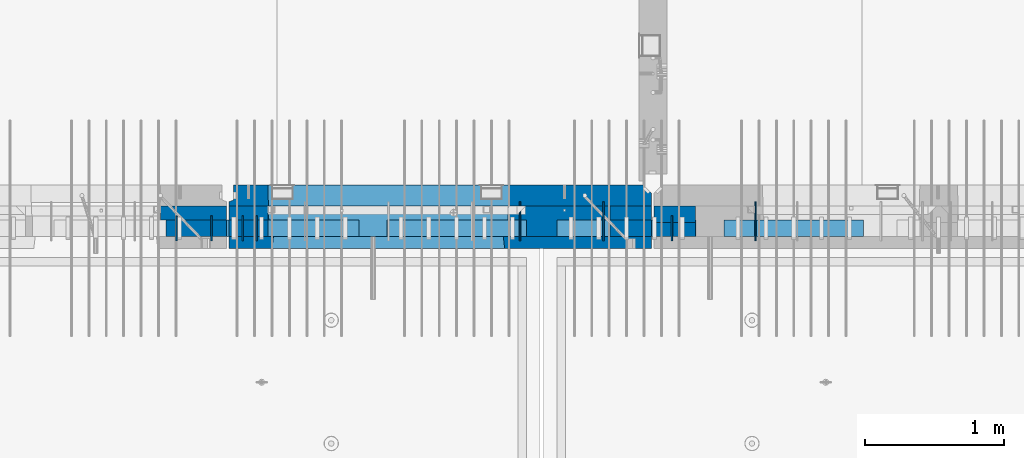
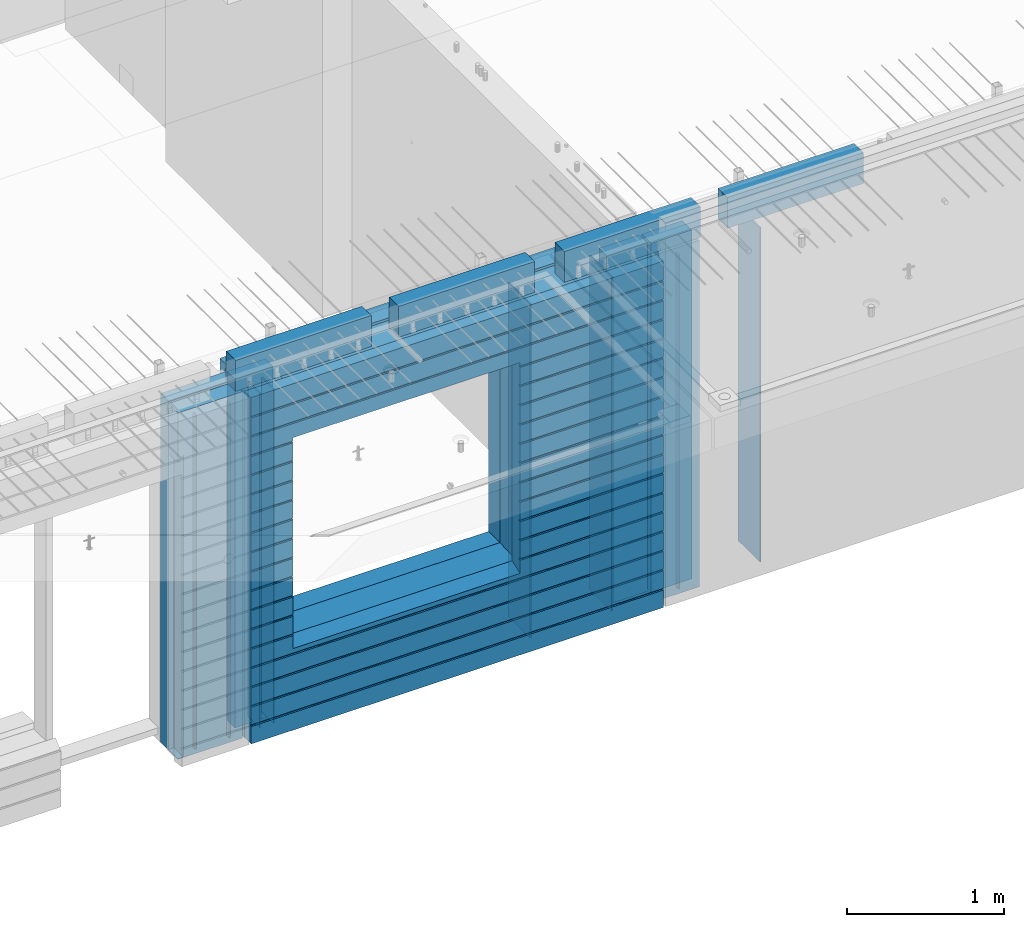
# One storey, part 233 of 350: 23 walls, 10 elements without a shape of their own.
"""IFC2X3 building model written with IfcOpenShell, lengths in millimetres."""

import ifcopenshell
import ifcopenshell.guid

model = None  # the IFC model being written
_history = None  # IfcOwnerHistory: only IFC2X3 demands one
_inside = {}  # id of a spatial element -> (the spatial element, [elements in it])
_under = {}  # id of a project, library or spatial element -> (it, [spatial elements below it])
_declared = {}  # id of a project -> (the project, [libraries it declares])
_typed = {}  # id of a type object -> (the type object, [elements of that type])
_made_of = {}  # id of a material, layer set ... -> (it, [elements and type objects made of it])


def new_model(schema):
    """Start an empty IFC model of exactly this schema.

    Asked for "IFC4X3", IfcOpenShell would pick the latest addendum, in which some entities
    have other attributes; the version numbers below select the first issue.
    IFC2X3 requires an IfcOwnerHistory on every rooted entity: one is made here for all.
    """
    global model, _history
    if schema == "IFC4X3":
        model = ifcopenshell.file(schema_version=(4, 3, 0, 0))
    else:
        model = ifcopenshell.file(schema=schema)
    _inside.clear()
    _under.clear()
    _declared.clear()
    _typed.clear()
    _made_of.clear()
    _history = None
    if model.schema == "IFC2X3":
        org = make("IfcOrganization", Name="unknown")
        user = make(
            "IfcPersonAndOrganization",
            ThePerson=make("IfcPerson", FamilyName="unknown"),
            TheOrganization=org,
        )
        app = make(
            "IfcApplication",
            ApplicationDeveloper=org,
            Version="unknown",
            ApplicationFullName="unknown",
            ApplicationIdentifier="unknown",
        )
        _history = make(
            "IfcOwnerHistory",
            OwningUser=user,
            OwningApplication=app,
            ChangeAction="ADDED",
            CreationDate=0,
        )
    return model


def make(cls, **values):
    """One entity of the class cls with the attributes given. An attribute that is None is left unset."""
    return model.create_entity(
        cls, **{name: value for name, value in values.items() if value is not None}
    )


def rooted(cls, **values):
    """An entity with a GlobalId (a new one), such as an element, a storey or a relation."""
    return make(cls, GlobalId=ifcopenshell.guid.new(), OwnerHistory=_history, **values)


def si_unit(unit_type, name, prefix=None):
    """IfcSIUnit, for example si_unit("LENGTHUNIT", "METRE", prefix="MILLI")."""
    return make("IfcSIUnit", UnitType=unit_type, Prefix=prefix, Name=name)


def assignment(units):
    """IfcUnitAssignment: the units of a project."""
    return None if units is None else make("IfcUnitAssignment", Units=units)


def point(xyz):
    """IfcCartesianPoint."""
    return None if xyz is None else make("IfcCartesianPoint", Coordinates=xyz)


def direction(xyz):
    """IfcDirection."""
    return None if xyz is None else make("IfcDirection", DirectionRatios=xyz)


def frame(location, z_axis=None, x_axis=None):
    """IfcAxis2Placement3D, a coordinate frame: its origin and axes. An axis left out is left unset."""
    return make(
        "IfcAxis2Placement3D",
        Location=point(location),
        Axis=direction(z_axis),
        RefDirection=direction(x_axis),
    )


def origin_with_axes():
    """The frame at (0, 0, 0) with the z axis (0, 0, 1) and the x axis (1, 0, 0) written out."""
    return frame((0.0, 0.0, 0.0), z_axis=(0.0, 0.0, 1.0), x_axis=(1.0, 0.0, 0.0))


def place(relative_to, where):
    """IfcLocalPlacement: puts the frame where relative to a parent placement (None: the world)."""
    return make(
        "IfcLocalPlacement", PlacementRelTo=relative_to, RelativePlacement=where
    )


def context(
    kind, dimensions, precision=None, world=None, true_north=None, identifier=None
):
    """IfcGeometricRepresentationContext, for example the 3D "Model" context."""
    return make(
        "IfcGeometricRepresentationContext",
        ContextIdentifier=identifier,
        ContextType=kind,
        CoordinateSpaceDimension=dimensions,
        Precision=precision,
        WorldCoordinateSystem=world,
        TrueNorth=true_north,
    )


def subcontext(parent, identifier, kind, view, scale=None):
    """IfcGeometricRepresentationSubContext, for example "Body" below "Model"."""
    return make(
        "IfcGeometricRepresentationSubContext",
        ContextIdentifier=identifier,
        ContextType=kind,
        ParentContext=parent,
        TargetScale=scale,
        TargetView=view,
    )


def project(units=None, contexts=None):
    """IfcProject with its units and contexts."""
    return rooted(
        "IfcProject",
        Name="project",
        RepresentationContexts=contexts,
        UnitsInContext=assignment(units),
    )


def spatial(cls, under=None, at=None, **own):
    """A site, building, storey or space (cls), placed at a placement, below another one or the project."""
    s = rooted(cls, ObjectPlacement=at, **own)
    if under is not None:
        _under.setdefault(under.id(), (under, []))[1].append(s)
    return s


def faces_of(points, faces, orient=None, outer=None):
    """IfcFace entities. A face is a list of loops; a loop is a list of indices into points, from 0.

    orient and outer hold one flag for each loop. By default every Orientation is true, the
    first loop of a face is its IfcFaceOuterBound and the others are IfcFaceBound.
    """
    made = []
    for i, loops in enumerate(faces):
        bounds = []
        for j, loop in enumerate(loops):
            is_outer = j == 0 if outer is None else outer[i][j]
            bounds.append(
                make(
                    "IfcFaceOuterBound" if is_outer else "IfcFaceBound",
                    Bound=make("IfcPolyLoop", Polygon=[points[k] for k in loop]),
                    Orientation=True if orient is None else orient[i][j],
                )
            )
        made.append(make("IfcFace", Bounds=bounds))
    return made


def faceted_brep(points, faces, orient=None, outer=None, voids=None):
    """IfcFacetedBrep: a solid bounded by flat faces; with voids (closed shells), ...WithVoids."""
    shared = [point(p) for p in points]
    hull = make("IfcClosedShell", CfsFaces=faces_of(shared, faces, orient, outer))
    if voids is None:
        return make("IfcFacetedBrep", Outer=hull)
    return make(
        "IfcFacetedBrepWithVoids",
        Outer=hull,
        Voids=[
            make(cls, CfsFaces=faces_of(shared, fs, o, b)) for cls, fs, o, b in voids
        ],
    )


def shape(context_of_items, identifier, shape_type, items):
    """IfcShapeRepresentation: the items that make up one representation, for example the "Body"."""
    return make(
        "IfcShapeRepresentation",
        ContextOfItems=context_of_items,
        RepresentationIdentifier=identifier,
        RepresentationType=shape_type,
        Items=items,
    )


def material(Name=None, Category=None):
    """IfcMaterial."""
    return make("IfcMaterial", Name=Name, Category=Category)


def made_of(thing, what):
    """Note that an element or type object is made of a material, layer set ...; save() writes the relation."""
    if what is not None:
        _made_of.setdefault(what.id(), (what, []))[1].append(thing)
    return thing


def type_object(cls, material=None, **own):
    """A type object (cls), such as IfcWallType, which elements share."""
    return made_of(rooted(cls, **own), material)


def element(
    cls,
    number,
    at=None,
    inside=None,
    cuts=None,
    type_object=None,
    material=None,
    context=None,
    identifier="Body",
    shape_type=None,
    held_by="IfcProductDefinitionShape",
    body=None,
    shapes=None,
    **own,
):
    """One element of the class cls, such as IfcWall. Its Tag is "e" and its number.

    at: its placement. inside: the storey or other place that contains it. cuts: it is an
    opening in that element (IfcRelVoidsElement). A single representation is given by context,
    identifier, shape_type and body (its items); several are given by shapes. held_by: the class
    of the entity that holds the representations. save() writes the other relations.
    """
    e = rooted(cls, Tag="e%d" % number, ObjectPlacement=at, **own)
    if body is not None:
        shapes = [shape(context, identifier, shape_type, body)]
    if shapes is not None:
        e.Representation = make(held_by, Representations=shapes)
    if inside is not None:
        _inside.setdefault(inside.id(), (inside, []))[1].append(e)
    if cuts is not None:
        rooted(
            "IfcRelVoidsElement", RelatingBuildingElement=cuts, RelatedOpeningElement=e
        )
    if type_object is not None:
        _typed.setdefault(type_object.id(), (type_object, []))[1].append(e)
    return made_of(e, material)


def aggregate(whole, parts):
    """IfcRelAggregates: a whole, such as a stair, and the parts it consists of."""
    return rooted("IfcRelAggregates", RelatingObject=whole, RelatedObjects=parts)


def save(model, path):
    """Write the relations noted so far, then the file.

    IfcRelAggregates (storeys below a building ...), IfcRelContainedInSpatialStructure (elements
    in a storey), IfcRelDefinesByType, IfcRelAssociatesMaterial and IfcRelDeclares: one each for
    every whole, place, type object, material and project.
    """
    for whole, parts in _under.values():
        aggregate(whole, parts)
    for where, things in _inside.values():
        rooted(
            "IfcRelContainedInSpatialStructure",
            RelatedElements=things,
            RelatingStructure=where,
        )
    for kind, things in _typed.values():
        rooted("IfcRelDefinesByType", RelatedObjects=things, RelatingType=kind)
    for what, things in _made_of.values():
        rooted("IfcRelAssociatesMaterial", RelatedObjects=things, RelatingMaterial=what)
    for by, libraries in _declared.values():
        rooted("IfcRelDeclares", RelatingContext=by, RelatedDefinitions=libraries)
    model.write(path)


model = new_model("IFC2X3")

# Units and contexts
model_context = context("Model", 3, precision=1e-05, world=origin_with_axes())
body_context = subcontext(model_context, "Body", "Model", "MODEL_VIEW")
ifc_project = project(units=[si_unit("LENGTHUNIT", "METRE", prefix="MILLI"), si_unit("AREAUNIT", "SQUARE_METRE"), si_unit("VOLUMEUNIT", "CUBIC_METRE"), si_unit("MASSUNIT", "GRAM", prefix="KILO"), si_unit("TIMEUNIT", "SECOND"), si_unit("PLANEANGLEUNIT", "RADIAN"), si_unit("SOLIDANGLEUNIT", "STERADIAN"), si_unit("THERMODYNAMICTEMPERATUREUNIT", "DEGREE_CELSIUS"), si_unit("LUMINOUSINTENSITYUNIT", "LUMEN")], contexts=[model_context])

# Site, building, storey
site_placement = place(None, origin_with_axes())
site = spatial("IfcSite", under=ifc_project, at=site_placement, CompositionType="ELEMENT")
building_placement = place(site_placement, origin_with_axes())
building = spatial("IfcBuilding", under=site, at=building_placement, CompositionType="ELEMENT")
storey_placement = place(building_placement, origin_with_axes())
storey = spatial("IfcBuildingStorey", under=building, at=storey_placement, Name="2", CompositionType="ELEMENT", Elevation=0.0)

# Assembly, walls
assembly_1_placement = place(storey_placement, origin_with_axes())
assembly_1 = element("IfcElementAssembly", 1, at=assembly_1_placement, inside=storey, AssemblyPlace="NOTDEFINED", PredefinedType="REINFORCEMENT_UNIT")
ifc_material_1 = material(Name="Undefined")
wall_type_1 = type_object("IfcWallType", PredefinedType="NOTDEFINED")
wall_1_placement = place(assembly_1_placement, frame((25665.0, 7780.0, 86115.0), z_axis=(0.0, 0.0, 1.0), x_axis=(0.0, -1.0, 0.0)))
wall_1 = element("IfcWall", 2, at=wall_1_placement, type_object=wall_type_1, material=ifc_material_1, Name="(PD)", context=body_context, shape_type="Brep", body=[
    faceted_brep([(0.0, 5.0, -1300.0), (0.0, 5.0, 1300.0), (180.0, 5.0, 1300.0), (180.0, 5.0, -1300.0), (0.0, -5.0, 1300.0), (180.0, -5.0, 1300.0), (0.0, -5.0, -1300.0), (180.0, -5.0, -1300.0)], [[[0, 1, 2, 3]], [[1, 4, 5, 2]], [[4, 6, 7, 5]], [[6, 0, 3, 7]], [[5, 7, 3, 2]], [[6, 4, 1, 0]]]),
])
wall_2_placement = place(assembly_1_placement, frame((25765.0, 7780.0, 86115.0), z_axis=(0.0, 0.0, 1.0), x_axis=(0.0, -1.0, 0.0)))
wall_2 = element("IfcWall", 3, at=wall_2_placement, type_object=wall_type_1, material=ifc_material_1, Name="(PD)", context=body_context, shape_type="Brep", body=[
    faceted_brep([(0.0, 5.0, -1300.0), (0.0, 5.0, 1300.0), (180.0, 5.0, 1300.0), (180.0, 5.0, -1300.0), (0.0, -5.0, 1300.0), (180.0, -5.0, 1300.0), (0.0, -5.0, -1300.0), (180.0, -5.0, -1300.0)], [[[0, 1, 2, 3]], [[1, 4, 5, 2]], [[4, 6, 7, 5]], [[6, 0, 3, 7]], [[5, 7, 3, 2]], [[6, 4, 1, 0]]]),
])
wall_3_placement = place(assembly_1_placement, frame((28255.0, 7880.0, 86115.0), z_axis=(0.0, 0.0, 1.0), x_axis=(0.0, -1.0, 0.0)))
wall_3 = element("IfcWall", 4, at=wall_3_placement, type_object=wall_type_1, material=ifc_material_1, Name="(PD)", context=body_context, shape_type="Brep", body=[
    faceted_brep([(0.0, 5.0, -1300.0), (0.0, 5.0, 1300.0), (280.0, 5.0, 1300.0), (280.0, 5.0, -1300.0), (0.0, -5.0, 1300.0), (280.0, -5.0, 1300.0), (0.0, -5.0, -1300.0), (280.0, -5.0, -1300.0)], [[[0, 1, 2, 3]], [[1, 4, 5, 2]], [[4, 6, 7, 5]], [[6, 0, 3, 7]], [[5, 7, 3, 2]], [[6, 4, 1, 0]]]),
])

# Assembly, wall
assembly_2_placement = place(storey_placement, origin_with_axes())
assembly_2 = element("IfcElementAssembly", 5, at=assembly_2_placement, inside=storey, AssemblyPlace="NOTDEFINED", PredefinedType="REINFORCEMENT_UNIT")
wall_4_placement = place(assembly_2_placement, frame((28745.0021834468, 7780.0, 86115.0), z_axis=(0.0, 0.0, 1.0), x_axis=(0.0, -1.0, 0.0)))
wall_4 = element("IfcWall", 6, at=wall_4_placement, type_object=wall_type_1, material=ifc_material_1, Name="(PD)", context=body_context, shape_type="Brep", body=[
    faceted_brep([(0.0, 5.0, -1300.0), (0.0, 5.0, 1300.0), (180.0, 5.0, 1300.0), (180.0, 5.0, -1300.0), (0.0, -5.0, 1300.0), (180.0, -5.0, 1300.0), (0.0, -5.0, -1300.0), (180.0, -5.0, -1300.0)], [[[0, 1, 2, 3]], [[1, 4, 5, 2]], [[4, 6, 7, 5]], [[6, 0, 3, 7]], [[5, 7, 3, 2]], [[6, 4, 1, 0]]]),
])

assembly_3_placement = place(storey_placement, origin_with_axes())
assembly_3 = element("IfcElementAssembly", 7, at=assembly_3_placement, inside=storey, Name="Steel Assembly", AssemblyPlace="NOTDEFINED", PredefinedType="NOTDEFINED")
wall_5_placement = place(assembly_3_placement, frame((29345.0021834468, 7880.0, 86115.0), z_axis=(0.0, 0.0, 1.0), x_axis=(0.0, -1.0, 0.0)))
wall_5 = element("IfcWall", 8, at=wall_5_placement, type_object=wall_type_1, material=ifc_material_1, Name="(PD)", context=body_context, shape_type="Brep", body=[
    faceted_brep([(0.0, 5.0, -1300.0), (0.0, 5.0, 1300.0), (280.0, 5.0, 1300.0), (280.0, 5.0, -1300.0), (0.0, -5.0, 1300.0), (280.0, -5.0, 1300.0), (0.0, -5.0, -1300.0), (280.0, -5.0, -1300.0)], [[[0, 1, 2, 3]], [[1, 4, 5, 2]], [[4, 6, 7, 5]], [[6, 0, 3, 7]], [[5, 7, 3, 2]], [[6, 4, 1, 0]]]),
])
aggregate(assembly_3, [wall_5])

# Assembly, walls
assembly_4_placement = place(storey_placement, origin_with_axes())
assembly_4 = element("IfcElementAssembly", 9, at=assembly_4_placement, inside=storey, AssemblyPlace="NOTDEFINED", PredefinedType="REINFORCEMENT_UNIT")
wall_6_placement = place(assembly_4_placement, frame((25190.0, 7780.0, 86115.0), z_axis=(0.0, 0.0, 1.0), x_axis=(0.0, -1.0, 0.0)))
wall_6 = element("IfcWall", 10, at=wall_6_placement, type_object=wall_type_1, material=ifc_material_1, Name="(PD)", context=body_context, shape_type="Brep", body=[
    faceted_brep([(0.0, 5.0, -1300.0), (0.0, 5.0, 1300.0), (180.0, 5.0, 1300.0), (180.0, 5.0, -1300.0), (0.0, -5.0, 1300.0), (180.0, -5.0, 1300.0), (0.0, -5.0, -1300.0), (180.0, -5.0, -1300.0)], [[[0, 1, 2, 3]], [[1, 4, 5, 2]], [[4, 6, 7, 5]], [[6, 0, 3, 7]], [[5, 7, 3, 2]], [[6, 4, 1, 0]]]),
])
wall_7_placement = place(assembly_4_placement, frame((25440.0, 7780.0, 86115.0), z_axis=(0.0, 0.0, 1.0), x_axis=(0.0, -1.0, 0.0)))
wall_7 = element("IfcWall", 11, at=wall_7_placement, type_object=wall_type_1, material=ifc_material_1, Name="(PD)", context=body_context, shape_type="Brep", body=[
    faceted_brep([(0.0, 5.0, -1300.0), (0.0, 5.0, 1300.0), (180.0, 5.0, 1300.0), (180.0, 5.0, -1300.0), (0.0, -5.0, 1300.0), (180.0, -5.0, 1300.0), (0.0, -5.0, -1300.0), (180.0, -5.0, -1300.0)], [[[0, 1, 2, 3]], [[1, 4, 5, 2]], [[4, 6, 7, 5]], [[6, 0, 3, 7]], [[5, 7, 3, 2]], [[6, 4, 1, 0]]]),
])

# Wall
wall_8_placement = place(assembly_1_placement, frame((27655.0, 7880.0, 86115.0), z_axis=(0.0, 0.0, 1.0), x_axis=(0.0, -1.0, 0.0)))
wall_8 = element("IfcWall", 12, at=wall_8_placement, type_object=wall_type_1, material=ifc_material_1, Name="(PD)", context=body_context, shape_type="Brep", body=[
    faceted_brep([(0.0, 5.0, -1300.0), (0.0, 5.0, 1300.0), (280.0, 5.0, 1300.0), (280.0, 5.0, -1300.0), (0.0, -5.0, 1300.0), (280.0, -5.0, 1300.0), (0.0, -5.0, -1300.0), (280.0, -5.0, -1300.0)], [[[0, 1, 2, 3]], [[1, 4, 5, 2]], [[4, 6, 7, 5]], [[6, 0, 3, 7]], [[5, 7, 3, 2]], [[6, 4, 1, 0]]]),
])

# Assemblies, walls
assembly_5_placement = place(storey_placement, origin_with_axes())
assembly_5 = element("IfcElementAssembly", 13, at=assembly_5_placement, inside=storey, AssemblyPlace="NOTDEFINED", PredefinedType="REINFORCEMENT_UNIT")
assembly_6_placement = place(assembly_5_placement, origin_with_axes())
assembly_6 = element("IfcElementAssembly", 14, at=assembly_6_placement, Name="Steel Assembly", AssemblyPlace="NOTDEFINED", PredefinedType="NOTDEFINED")
ifc_material_2 = material()
wall_type_2 = type_object("IfcWallType", PredefinedType="NOTDEFINED")
wall_9_placement = place(assembly_6_placement, frame((26699.9998568133, 7690.00021946163, 87590.0), z_axis=(0.0, 0.0, 1.0), x_axis=(1.0, 0.0, 0.0)))
wall_9 = element("IfcWall", 15, at=wall_9_placement, type_object=wall_type_2, material=ifc_material_2, context=body_context, shape_type="Brep", body=[
    faceted_brep([(0.0, 60.0, -120.0), (0.0, 60.0, 120.0), (1000.0, 60.0, 120.0), (1000.0, 60.0, -120.0), (0.0, -60.0, 120.0), (1000.0, -60.0, 120.0), (0.0, -60.0, -120.0), (1000.0, -60.0, -120.0)], [[[0, 1, 2, 3]], [[1, 4, 5, 2]], [[4, 6, 7, 5]], [[6, 0, 3, 7]], [[5, 7, 3, 2]], [[6, 4, 1, 0]]]),
])
aggregate(assembly_6, [wall_9])
assembly_7_placement = place(assembly_5_placement, origin_with_axes())
assembly_7 = element("IfcElementAssembly", 16, at=assembly_7_placement, Name="Steel Assembly", AssemblyPlace="NOTDEFINED", PredefinedType="NOTDEFINED")
aggregate(assembly_5, [assembly_7, assembly_6])
wall_10_placement = place(assembly_7_placement, frame((25499.9998568133, 7690.00021946163, 87590.0), z_axis=(0.0, 0.0, 1.0), x_axis=(1.0, 0.0, 0.0)))
wall_10 = element("IfcWall", 17, at=wall_10_placement, type_object=wall_type_2, material=ifc_material_2, context=body_context, shape_type="Brep", body=[
    faceted_brep([(0.0, 60.0, -120.0), (0.0, 60.0, 120.0), (1000.0, 60.0, 120.0), (1000.0, 60.0, -120.0), (0.0, -60.0, 120.0), (1000.0, -60.0, 120.0), (0.0, -60.0, -120.0), (1000.0, -60.0, -120.0)], [[[0, 1, 2, 3]], [[1, 4, 5, 2]], [[4, 6, 7, 5]], [[6, 0, 3, 7]], [[5, 7, 3, 2]], [[6, 4, 1, 0]]]),
])
aggregate(assembly_7, [wall_10])

assembly_8_placement = place(storey_placement, origin_with_axes())
assembly_8 = element("IfcElementAssembly", 18, at=assembly_8_placement, inside=storey, AssemblyPlace="NOTDEFINED", PredefinedType="REINFORCEMENT_UNIT")
assembly_9_placement = place(assembly_8_placement, origin_with_axes())
assembly_9 = element("IfcElementAssembly", 19, at=assembly_9_placement, Name="Steel Assembly", AssemblyPlace="NOTDEFINED", PredefinedType="NOTDEFINED")
wall_11_placement = place(assembly_9_placement, frame((29119.9998568133, 7690.00021946163, 87590.0), z_axis=(0.0, 0.0, 1.0), x_axis=(1.0, 0.0, 0.0)))
wall_11 = element("IfcWall", 20, at=wall_11_placement, type_object=wall_type_2, material=ifc_material_2, context=body_context, shape_type="Brep", body=[
    faceted_brep([(0.0, 60.0, -120.0), (0.0, 60.0, 120.0), (1000.0, 60.0, 120.0), (1000.0, 60.0, -120.0), (0.0, -60.0, 120.0), (1000.0, -60.0, 120.0), (0.0, -60.0, -120.0), (1000.0, -60.0, -120.0)], [[[0, 1, 2, 3]], [[1, 4, 5, 2]], [[4, 6, 7, 5]], [[6, 0, 3, 7]], [[5, 7, 3, 2]], [[6, 4, 1, 0]]]),
])
aggregate(assembly_9, [wall_11])
assembly_10_placement = place(assembly_8_placement, origin_with_axes())
assembly_10 = element("IfcElementAssembly", 21, at=assembly_10_placement, Name="Steel Assembly", AssemblyPlace="NOTDEFINED", PredefinedType="NOTDEFINED")
aggregate(assembly_8, [assembly_10, assembly_9])
wall_12_placement = place(assembly_10_placement, frame((27919.9998568133, 7690.00021946163, 87590.0), z_axis=(0.0, 0.0, 1.0), x_axis=(1.0, 0.0, 0.0)))
wall_12 = element("IfcWall", 22, at=wall_12_placement, type_object=wall_type_2, material=ifc_material_2, context=body_context, shape_type="Brep", body=[
    faceted_brep([(0.0, 60.0, -120.0), (0.0, 60.0, 120.0), (1000.0, 60.0, 120.0), (1000.0, 60.0, -120.0), (0.0, -60.0, 120.0), (1000.0, -60.0, 120.0), (0.0, -60.0, -120.0), (1000.0, -60.0, -120.0)], [[[0, 1, 2, 3]], [[1, 4, 5, 2]], [[4, 6, 7, 5]], [[6, 0, 3, 7]], [[5, 7, 3, 2]], [[6, 4, 1, 0]]]),
])
aggregate(assembly_10, [wall_12])

# Wall
ifc_material_3 = material(Name="CONCRETE/C35/45")
wall_type_3 = type_object("IfcWallType", PredefinedType="NOTDEFINED")
wall_13_placement = place(assembly_1_placement, frame((28600.0, 7925.0, 86112.5), z_axis=(0.0, 0.0, 1.0), x_axis=(-1.0, 3.00000001838171e-08, 0.0)))
wall_13 = element("IfcWall", 23, at=wall_13_placement, type_object=wall_type_3, material=ifc_material_3, context=body_context, shape_type="Brep", body=[
    faceted_brep([(0.0, 75.0, 1357.5), (0.0, 75.0, -1357.5), (0.0, -15.0, -1357.5), (0.0, -15.0, 1357.5), (60.0, -75.0, -1357.5), (3035.00000000003, 75.0, -1357.5), (3035.00000000003, 45.0, -1357.5), (3002.5, 32.0, -1357.5), (3002.5, -75.0, -1357.5), (60.0, -75.0, 1357.5), (3035.00000000003, 45.0, 1357.5), (3035.00000000003, 75.0, 1357.5), (3002.5, -75.0, 1357.5), (3002.5, 32.0, 1357.5), (2755.00051719707, -75.0, -682.5), (1025.00051719707, -75.0, -682.5), (1025.00051719707, -75.0, 952.5), (2755.00051719707, -75.0, 952.5), (2750.94646314301, 75.0, -678.445945945947), (1029.05457125112, 75.0, -678.445945945947), (1029.05457125112, 75.0, 948.445945945947), (2750.94646314301, 75.0, 948.445945945947)], [[[0, 1, 2, 3]], [[4, 2, 1, 5, 6, 7, 8]], [[3, 2, 4, 9]], [[10, 11, 0, 3, 9, 12, 13]], [[5, 11, 10, 6]], [[13, 7, 6, 10]], [[12, 8, 7, 13]], [[9, 4, 8, 12], [14, 15, 16, 17]], [[14, 18, 19, 15]], [[15, 19, 20, 16]], [[1, 0, 11, 5], [18, 21, 20, 19]], [[16, 20, 21, 17]], [[18, 14, 17, 21]]]),
])

wall_type_4 = type_object("IfcWallType", PredefinedType="NOTDEFINED")
wall_14_placement = place(assembly_1_placement, frame((28600.0000381475, 7800.0, 86112.5), z_axis=(0.0, 0.0, 1.0), x_axis=(-1.0, 3.00000001838171e-08, 0.0)))
wall_14 = element("IfcWall", 24, at=wall_14_placement, type_object=wall_type_4, material=ifc_material_3, context=body_context, shape_type="Brep", body=[
    faceted_brep([(0.0, 50.0, -1357.5), (0.0, 50.0, 1357.5), (300.001908754726, 50.0, 1357.5), (300.001908754726, 50.0, -1357.5), (0.0, -50.0, 1357.5), (300.001908754726, -50.0, 1357.5), (0.0, -50.0, -1357.5), (300.001908754726, -50.0, -1357.5)], [[[0, 1, 2, 3]], [[1, 4, 5, 2]], [[4, 6, 7, 5]], [[6, 0, 3, 7]], [[5, 7, 3, 2]], [[6, 4, 1, 0]]]),
])

wall_15_placement = place(assembly_4_placement, frame((25550.0000381475, 7800.00011629906, 86112.5), z_axis=(0.0, 0.0, 1.0), x_axis=(-1.0, 3.00000001838171e-08, 0.0)))
wall_15 = element("IfcWall", 25, at=wall_15_placement, type_object=wall_type_4, material=ifc_material_3, context=body_context, shape_type="Brep", body=[
    faceted_brep([(0.0, 50.0, -1357.5), (0.0, 50.0, 1357.5), (475.001908754726, 50.0, 1357.5), (475.001908754726, 50.0, -1357.5), (0.0, -50.0, 1357.5), (475.001908754726, -50.0, 1357.5), (0.0, -50.0, -1357.5), (475.001908754726, -50.0, -1357.5)], [[[0, 1, 2, 3]], [[1, 4, 5, 2]], [[4, 6, 7, 5]], [[6, 0, 3, 7]], [[5, 7, 3, 2]], [[6, 4, 1, 0]]]),
])

wall_16_placement = place(assembly_1_placement, frame((25845.0000381475, 7800.0, 86112.5), z_axis=(0.0, 0.0, 1.0), x_axis=(-1.0, 3.00000001838171e-08, 0.0)))
wall_16 = element("IfcWall", 26, at=wall_16_placement, type_object=wall_type_4, material=ifc_material_3, context=body_context, shape_type="Brep", body=[
    faceted_brep([(0.0, 50.0, -1357.5), (0.0, 50.0, 1357.5), (280.001908754726, 50.0, 1357.5), (280.001908754726, 50.0, -1357.5), (0.0, -50.0, 1357.5), (280.001908754726, -50.0, 1357.5), (0.0, -50.0, -1357.5), (280.001908754726, -50.0, -1357.5)], [[[0, 1, 2, 3]], [[1, 4, 5, 2]], [[4, 6, 7, 5]], [[6, 0, 3, 7]], [[5, 7, 3, 2]], [[6, 4, 1, 0]]]),
])

ifc_material_4 = material(Name="SPU")
wall_type_5 = type_object("IfcWallType", PredefinedType="NOTDEFINED")
wall_17_placement = place(assembly_4_placement, frame((25550.0000381475, 7690.00011629906, 86102.5), z_axis=(0.0, 0.0, 1.0), x_axis=(-1.0, 3.00000001838171e-08, 0.0)))
wall_17 = element("IfcWall", 27, at=wall_17_placement, type_object=wall_type_5, material=ifc_material_4, context=body_context, shape_type="Brep", body=[
    faceted_brep([(475.001908754726, -60.0, -1342.5), (475.001908754726, 60.0, -1342.5), (435.000555344595, 60.0001162990557, -1342.5), (435.000555344595, -59.9998837009443, -1342.5), (435.000555344595, -59.9998837009443, 1002.5), (435.000555344595, 60.0001162990557, 1002.5), (475.001908754726, 60.0, 962.498646589869), (475.001908754726, -60.0, 962.498646589869), (0.0, -60.0, -1347.5), (0.0, 60.0, -1347.5), (475.001908754726, 60.0, -1347.5), (475.001908754726, -60.0, -1347.5), (0.0, -60.0, 1347.5), (0.0, 60.0, 1347.5), (475.001908754726, -60.0, 1347.5), (475.001908754726, 60.0, 1347.5)], [[[0, 1, 2, 3]], [[4, 5, 6, 7]], [[3, 2, 5, 4]], [[8, 9, 10, 11]], [[8, 12, 13, 9]], [[13, 12, 14, 15]], [[15, 14, 7, 6]], [[1, 10, 9, 13, 15, 6, 5, 2]], [[11, 10, 1, 0]], [[14, 12, 8, 11, 0, 3, 4, 7]]]),
])

aggregate(assembly_4, [wall_17, wall_15, wall_6, wall_7])

wall_18_placement = place(assembly_1_placement, frame((28600.0000381475, 7690.0, 86102.5), z_axis=(0.0, 0.0, 1.0), x_axis=(-1.0, 3.00000001838171e-08, 0.0)))
wall_18 = element("IfcWall", 28, at=wall_18_placement, type_object=wall_type_5, material=ifc_material_4, context=body_context, shape_type="Brep", body=[
    faceted_brep([(0.0, 60.0, -1347.5), (0.0, 60.0, 1347.5), (300.001908754726, 60.0, 1347.5), (300.001908754726, 60.0, -1347.5), (0.0, -60.0, 1347.5), (300.001908754726, -60.0, 1347.5), (0.0, -60.0, -1347.5), (300.001908754726, -60.0, -1347.5)], [[[0, 1, 2, 3]], [[1, 4, 5, 2]], [[4, 6, 7, 5]], [[6, 0, 3, 7]], [[5, 7, 3, 2]], [[6, 4, 1, 0]]]),
])

wall_19_placement = place(assembly_1_placement, frame((25845.0000381475, 7690.0, 86102.5), z_axis=(0.0, 0.0, 1.0), x_axis=(-1.0, 3.00000001838171e-08, 0.0)))
wall_19 = element("IfcWall", 29, at=wall_19_placement, type_object=wall_type_5, material=ifc_material_4, context=body_context, shape_type="Brep", body=[
    faceted_brep([(0.0, 60.0, -1347.5), (0.0, 60.0, 1347.5), (280.001908754726, 60.0, 1347.5), (280.001908754726, 60.0, -1347.5), (0.0, -60.0, 1347.5), (280.001908754726, -60.0, 1347.5), (0.0, -60.0, -1347.5), (280.001908754726, -60.0, -1347.5)], [[[0, 1, 2, 3]], [[1, 4, 5, 2]], [[4, 6, 7, 5]], [[6, 0, 3, 7]], [[5, 7, 3, 2]], [[6, 4, 1, 0]]]),
])

wall_type_6 = type_object("IfcWallType", PredefinedType="NOTDEFINED")
wall_20_placement = place(assembly_2_placement, frame((28915.0000381475, 7680.0, 86102.5), z_axis=(0.0, 0.0, 1.0), x_axis=(-1.0, 3.00000001838171e-08, 0.0)))
wall_20 = element("IfcWall", 30, at=wall_20_placement, type_object=wall_type_6, material=ifc_material_4, context=body_context, shape_type="Brep", body=[
    faceted_brep([(0.0, 50.0, -1347.5), (0.0, 50.0, 1347.5), (300.001908754726, 50.0, 1347.5), (300.001908754726, 50.0, -1347.5), (0.0, -50.0, 1347.5), (300.001908754726, -50.0, 1347.5), (0.0, -50.0, -1347.5), (300.001908754726, -50.0, -1347.5)], [[[0, 1, 2, 3]], [[1, 4, 5, 2]], [[4, 6, 7, 5]], [[6, 0, 3, 7]], [[5, 7, 3, 2]], [[6, 4, 1, 0]]]),
])

wall_type_7 = type_object("IfcWallType", PredefinedType="NOTDEFINED")
wall_21_placement = place(assembly_2_placement, frame((28915.0000381475, 7790.0, 86112.5), z_axis=(0.0, 0.0, 1.0), x_axis=(-1.0, 3.00000001838171e-08, 0.0)))
wall_21 = element("IfcWall", 31, at=wall_21_placement, type_object=wall_type_7, material=ifc_material_3, context=body_context, shape_type="Brep", body=[
    faceted_brep([(0.0, 60.0, -1357.5), (0.0, 60.0, 1357.5), (300.001908754726, 60.0, 1357.5), (300.001908754726, 60.0, -1357.5), (0.0, -60.0, 1357.5), (300.001908754726, -60.0, 1357.5), (0.0, -60.0, -1357.5), (300.001908754726, -60.0, -1357.5)], [[[0, 1, 2, 3]], [[1, 4, 5, 2]], [[4, 6, 7, 5]], [[6, 0, 3, 7]], [[5, 7, 3, 2]], [[6, 4, 1, 0]]]),
])

aggregate(assembly_2, [wall_20, wall_21, wall_4])

ifc_material_5 = material(Name="CONCRETE/C30/37")
wall_type_8 = type_object("IfcWallType", PredefinedType="NOTDEFINED")
wall_22_placement = place(assembly_1_placement, frame((28600.0, 7587.5, 86102.5), z_axis=(0.0, 0.0, 1.0), x_axis=(-1.0, 3.00000001838171e-08, 0.0)))
wall_22 = element("IfcWall", 32, at=wall_22_placement, type_object=wall_type_8, material=ifc_material_5, context=body_context, shape_type="Brep", body=[
    faceted_brep([(3.63797880709171e-12, 32.4999991119639, 1050.00000040043), (3035.0, 32.4999991119785, 1050.00000040044), (3035.0, 32.4999992499725, 1039.99999999921), (3.63797880709171e-12, 32.4999992499725, 1039.99999999921), (0.0, 42.5, 1051.99999988925), (3035.0, 42.5, 1051.99999988925), (0.0, 42.5, 1187.99999994476), (3035.0, 42.5, 1187.99999994476), (-3.63797880709171e-12, 32.499999249967, 1189.99999999923), (3035.0, 32.4999992499634, 1189.99999999921), (-3.63797880709171e-12, 32.4999991119576, 1200.00000040043), (3035.0, 32.4999991119703, 1200.00000040044), (0.0, 42.5, 1201.99999988925), (3035.0, 42.5, 1201.99999988925), (0.0, 42.5, 1347.5), (3035.0, 42.5, 1347.5), (0.0, -42.5, 1347.5), (3035.0, -42.5, 1347.5), (0.0, -42.5, -1347.5), (0.0, 42.5, -1347.5), (3035.0, 42.5, -1347.5), (3035.0, -42.5, -1347.5), (0.0, 42.5, -1212.00000005524), (3035.0, 42.5, -1212.00000005524), (0.0, 32.4999992501671, -1210.00000000079), (3035.0, 32.4999992501644, -1210.0000000008), (0.0, 32.4999991121604, -1199.99999959957), (3035.0, 32.4999991121604, -1199.99999959957), (0.0, 42.5, -1198.00000011075), (3035.0, 42.5, -1198.00000011075), (0.0, 42.5, -1062.00000005522), (3035.0, 42.5, -1062.00000005522), (0.0, 32.4999992506973, -1060.00000000076), (3035.0, 32.4999992506928, -1060.00000000079), (0.0, 32.4999991126861, -1049.99999959956), (3035.0, 32.4999991126924, -1049.99999959956), (0.0, 42.5, -1048.00000011074), (3035.0, 42.5, -1048.00000011074), (0.0, 42.5, -912.000000055254), (3035.0, 42.5, -912.000000055254), (0.0, 32.4999992512376, -910.000000000786), (3035.0, 32.4999992512339, -910.000000000815), (0.0, 32.499999113239, -899.99999959959), (3035.0, 32.4999991132327, -899.99999959959), (0.0, 42.5, -898.000000110769), (3035.0, 42.5, -898.000000110769), (0.0, 42.5, -762.000000055225), (3035.0, 42.5, -762.000000055225), (0.0, 32.4999992517696, -760.000000000757), (3035.0, 32.499999251766, -760.000000000786), (0.0, 32.4999991137702, -749.99999959956), (3035.0, 32.4999991137656, -749.99999959956), (0.0, 42.5, -748.00000011074), (3035.0, 42.5, -748.00000011074), (3035.0, 42.5, 901.999999889245), (3035.0, 32.4999991119894, 900.00000040044), (2723.82404650436, 32.4999991119894, 900.00000040044), (2725.00051719707, 42.5, 901.999999889245), (3035.0, 32.4999992499834, 889.999999999214), (2723.82404652059, 32.4999992499834, 889.999999999214), (3035.0, 42.5, 887.999999944761), (2725.00051719707, 42.5, 887.999999944761), (3035.0, 42.5, 751.999999889245), (2725.00051719707, 42.5, 751.999999889245), (3035.0, 32.4999991119967, 750.000000400425), (2723.82404650436, 32.4999991119967, 750.000000400425), (3035.0, 32.4999992499961, 739.9999999992), (2723.82404652059, 32.4999992499961, 739.9999999992), (3035.0, 42.5, 737.999999944761), (2725.00051719707, 42.5, 737.999999944761), (3035.0, 42.5, 601.99999988926), (2725.00051719707, 42.5, 601.99999988926), (3035.0, 32.4999991120212, 600.000000400454), (2723.82404650436, 32.4999991120212, 600.000000400454), (3035.0, 32.4999992500161, 589.999999999229), (2723.8240465206, 32.4999992500161, 589.999999999229), (3035.0, 42.5, 587.999999944775), (2725.00051719707, 42.5, 587.999999944775), (3035.0, 42.5, 451.999999889231), (2725.00051719707, 42.5, 451.999999889231), (3035.0, 32.4999991120285, 450.000000400425), (2723.82404650436, 32.4999991120285, 450.000000400425), (3035.0, 32.4999992500234, 439.9999999992), (2723.8240465206, 32.4999992500234, 439.9999999992), (3035.0, 42.5, 437.999999944746), (2725.00051719707, 42.5, 437.999999944746), (3035.0, 42.5, 301.999999889245), (2725.00051719707, 42.5, 301.999999889245), (3035.0, 32.4999991120458, 300.00000040044), (2723.82404650437, 32.4999991120458, 300.00000040044), (3035.0, 32.4999992500389, 289.999999999214), (2723.8240465206, 32.4999992500389, 289.999999999214), (3035.0, 42.5, 287.999999944761), (2725.00051719707, 42.5, 287.999999944761), (3035.0, 42.5, 151.99999988926), (2725.00051719707, 42.5, 151.99999988926), (3035.0, 32.4999991120585, 150.000000400454), (2723.82404650437, 32.4999991120585, 150.000000400454), (3035.0, 32.4999992500534, 139.999999999229), (2723.8240465206, 32.4999992500534, 139.999999999229), (3035.0, 42.5, 137.999999944775), (2725.00051719707, 42.5, 137.999999944775), (3035.0, 42.5, 1.99999988924537), (2725.00051719707, 42.5, 1.99999988924537), (3035.0, 32.4999992522926, -610.0000000008), (3035.0, 42.5, -612.000000055239), (2725.00051719707, 42.5, -612.000000055239), (2723.82404652087, 32.4999992522926, -610.0000000008), (3035.0, 32.4999991142904, -599.999999599575), (2723.82404650463, 32.4999991142904, -599.999999599575), (3035.0, 42.5, -598.000000110755), (2725.00051719707, 42.5, -598.000000110755), (3035.0, 42.5, -462.000000055239), (2725.00051719707, 42.5, -462.000000055239), (3035.0, 32.4999992528319, -460.0000000008), (2723.82404652093, 32.4999992528319, -460.0000000008), (3035.0, 32.4999991148297, -449.999999599575), (2723.82404650469, 32.4999991148297, -449.999999599575), (3035.0, 42.5, -448.000000110755), (2725.00051719707, 42.5, -448.000000110755), (3035.0, 42.5, -312.000000055254), (2725.00051719707, 42.5, -312.000000055254), (3035.0, 32.4999992533585, -310.000000000815), (2723.82404652099, 32.4999992533585, -310.000000000815), (3035.0, 32.4999991153563, -299.99999959959), (2723.82404650475, 32.4999991153563, -299.99999959959), (3035.0, 42.5, -298.000000110769), (2725.00051719707, 42.5, -298.000000110769), (3035.0, 42.5, -162.000000055239), (2725.00051719707, 42.499999923677, -162.000000055239), (3035.0, 32.4999992538951, -160.0000000008), (2723.82404652105, 32.4999992538951, -160.0000000008), (3035.0, 32.4999991158938, -149.999999599575), (2723.82404650482, 32.4999991158938, -149.999999599575), (3035.0, 42.5, -148.000000110755), (2725.00051719707, 42.4999999210722, -148.000000110755), (3035.0, 42.5, -12.0000000552391), (2725.00051719707, 42.5, -12.0000000552391), (3035.0, 32.4999992538906, -10.0000000008004), (2723.82404652105, 32.4999992538906, -10.0000000008004), (3035.0, 32.4999991158902, 4.00425051338971e-07), (2723.82404650482, 32.4999991158902, 4.00425051338971e-07), (3035.0, 42.5, 1037.99999994476), (0.0, 42.5, 1037.99999994476), (3.63797880709171e-12, 32.4999992499852, 889.999999999229), (3.63797880709171e-12, 32.4999991119857, 900.000000400425), (1056.17698788978, 32.4999991119894, 900.00000040044), (1056.17698787354, 32.4999992499834, 889.999999999214), (0.0, 42.5, 887.999999944761), (1055.00051719707, 42.5, 887.999999944761), (0.0, 42.5, 751.999999889245), (1055.00051719707, 42.5, 751.999999889245), (0.0, 32.4999991120039, 750.00000040044), (1056.17698788978, 32.4999991119967, 750.000000400425), (0.0, 32.4999992499997, 739.999999999229), (1056.17698787354, 32.4999992499961, 739.9999999992), (0.0, 42.5, 737.999999944761), (1055.00051719707, 42.5, 737.999999944761), (0.0, 42.5, 601.99999988926), (1055.00051719707, 42.5, 601.99999988926), (0.0, 32.4999991120094, 600.00000040044), (1056.17698788977, 32.4999991120212, 600.000000400454), (0.0, 32.499999250017, 589.999999999229), (1056.17698787354, 32.4999992500161, 589.999999999229), (0.0, 42.5, 587.999999944775), (1055.00051719707, 42.5, 587.999999944775), (0.0, 42.5, 451.999999889231), (1055.00051719707, 42.5, 451.999999889231), (0.0, 32.4999991120258, 450.000000400411), (1056.17698788977, 32.4999991120285, 450.000000400425), (0.0, 32.4999992500289, 439.999999999214), (1056.17698787354, 32.4999992500234, 439.9999999992), (0.0, 42.5, 437.999999944746), (1055.00051719707, 42.5, 437.999999944746), (0.0, 42.5, 301.999999889245), (1055.00051719707, 42.5, 301.999999889245), (-3.63797880709171e-12, 32.4999991120458, 300.00000040044), (1056.17698788977, 32.4999991120458, 300.00000040044), (-3.63797880709171e-12, 32.4999992500416, 289.999999999229), (1056.17698787353, 32.4999992500389, 289.999999999214), (0.0, 42.5, 287.999999944761), (1055.00051719707, 42.5, 287.999999944761), (0.0, 42.5, 151.99999988926), (1055.00051719707, 42.5, 151.99999988926), (0.0, 32.4999991120549, 150.00000040044), (1056.17698788977, 32.4999991120585, 150.000000400454), (0.0, 32.4999992500552, 139.999999999229), (1056.17698787353, 32.4999992500534, 139.999999999229), (0.0, 42.5, 137.999999944775), (1055.00051719707, 42.5, 137.999999944775), (0.0, 42.5, 1.99999988924537), (1055.00051719707, 42.5, 1.99999988924537), (0.0, 42.5, -12.0000000552391), (0.0, 42.5, -148.000000110755), (0.0, 32.4999991158993, -149.99999959956), (0.0, 32.4999992538978, -160.000000000757), (0.0, 42.5, -162.000000055239), (0.0, 42.5, -298.000000110769), (0.0, 32.4999991153618, -299.99999959959), (0.0, 32.4999992533649, -310.000000000786), (0.0, 42.5, -312.000000055254), (0.0, 42.5, -448.000000110755), (0.0, 32.4999991148252, -449.999999599575), (0.0, 32.4999992528365, -460.000000000771), (0.0, 42.5, -462.000000055239), (0.0, 42.5, -598.000000110755), (0.0, 32.4999991143004, -599.99999959956), (0.0, 32.4999992522971, -610.000000000771), (0.0, 42.5, -612.000000055239), (0.0, 42.5, 901.999999889245), (0.0, 32.4999991158911, 4.00425051338971e-07), (0.0, 32.4999992538942, -10.0000000007858), (1056.17698788932, 32.4999991158902, 4.00425051338971e-07), (1056.17698787308, 32.4999992538906, -10.0000000008004), (1055.00051719707, 42.5, -12.0000000552391), (1055.00051719707, 42.4999994958771, -148.000000110755), (1056.17698788932, 32.4999991158938, -149.999999599575), (1056.17698787308, 32.4999992538951, -160.0000000008), (1055.00051719707, 42.499999512519, -162.000000055239), (1055.00051719707, 42.5, -298.000000110769), (1056.17698788938, 32.4999991153563, -299.99999959959), (1056.17698787315, 32.4999992533585, -310.000000000815), (1055.00051719707, 42.5, -312.000000055254), (1055.00051719707, 42.5, -448.000000110755), (1056.17698788944, 32.4999991148297, -449.999999599575), (1056.17698787321, 32.4999992528319, -460.0000000008), (1055.00051719707, 42.5, -462.000000055239), (1055.00051719707, 42.5, -598.000000110755), (1056.1769878895, 32.4999991142904, -599.999999599575), (1056.17698787327, 32.4999992522926, -610.0000000008), (1055.00051719707, 42.5, -612.000000055239), (2725.00051719707, 42.5, -712.5), (1055.00051719707, 42.5, -712.5), (2715.00051719707, -42.5, 927.5), (2715.00051719707, -42.5, 932.5), (2725.00051719707, 42.5, 927.5), (2715.00051719707, -42.5, -662.5), (1065.00051719707, -42.5, -662.5), (1065.00051719707, -42.5, 927.5), (1065.00051719707, -42.5, 932.5), (1065.00051719707, 42.5, 927.5), (2715.00051719707, 42.5, 927.5), (1055.00051719707, 42.5, 927.5), (1055.00051719707, 42.5, 901.999999889245)], [[[0, 1, 2, 3]], [[4, 5, 1, 0]], [[5, 4, 6, 7]], [[8, 9, 7, 6]], [[10, 11, 9, 8]], [[12, 13, 11, 10]], [[14, 15, 13, 12]], [[14, 16, 17, 15]], [[18, 19, 20, 21]], [[20, 19, 22, 23]], [[24, 25, 23, 22]], [[26, 27, 25, 24]], [[28, 29, 27, 26]], [[29, 28, 30, 31]], [[32, 33, 31, 30]], [[34, 35, 33, 32]], [[36, 37, 35, 34]], [[37, 36, 38, 39]], [[40, 41, 39, 38]], [[42, 43, 41, 40]], [[44, 45, 43, 42]], [[45, 44, 46, 47]], [[48, 49, 47, 46]], [[50, 51, 49, 48]], [[52, 53, 51, 50]], [[54, 55, 56, 57]], [[55, 58, 59, 56]], [[58, 60, 61, 59]], [[60, 62, 63, 61]], [[62, 64, 65, 63]], [[64, 66, 67, 65]], [[66, 68, 69, 67]], [[68, 70, 71, 69]], [[70, 72, 73, 71]], [[72, 74, 75, 73]], [[74, 76, 77, 75]], [[76, 78, 79, 77]], [[78, 80, 81, 79]], [[80, 82, 83, 81]], [[82, 84, 85, 83]], [[84, 86, 87, 85]], [[86, 88, 89, 87]], [[88, 90, 91, 89]], [[90, 92, 93, 91]], [[92, 94, 95, 93]], [[94, 96, 97, 95]], [[96, 98, 99, 97]], [[98, 100, 101, 99]], [[100, 102, 103, 101]], [[104, 105, 106, 107]], [[108, 104, 107, 109]], [[110, 108, 109, 111]], [[112, 110, 111, 113]], [[114, 112, 113, 115]], [[116, 114, 115, 117]], [[118, 116, 117, 119]], [[120, 118, 119, 121]], [[122, 120, 121, 123]], [[124, 122, 123, 125]], [[126, 124, 125, 127]], [[128, 126, 127, 129]], [[130, 128, 129, 131]], [[132, 130, 131, 133]], [[134, 132, 133, 135]], [[136, 134, 135, 137]], [[138, 136, 137, 139]], [[140, 138, 139, 141]], [[102, 140, 141, 103]], [[100, 98, 96, 94, 92, 90, 88, 86, 84, 82, 80, 78, 76, 74, 72, 70, 68, 66, 64, 62, 60, 58, 55, 54, 142, 2, 1, 5, 7, 9, 11, 13, 15, 17, 21, 20, 23, 25, 27, 29, 31, 33, 35, 37, 39, 41, 43, 45, 47, 49, 51, 53, 105, 104, 108, 110, 112, 114, 116, 118, 120, 122, 124, 126, 128, 130, 132, 134, 136, 138, 140, 102]], [[3, 2, 142, 143]], [[144, 145, 146, 147]], [[148, 144, 147, 149]], [[150, 148, 149, 151]], [[152, 150, 151, 153]], [[154, 152, 153, 155]], [[156, 154, 155, 157]], [[158, 156, 157, 159]], [[160, 158, 159, 161]], [[162, 160, 161, 163]], [[164, 162, 163, 165]], [[166, 164, 165, 167]], [[168, 166, 167, 169]], [[170, 168, 169, 171]], [[172, 170, 171, 173]], [[174, 172, 173, 175]], [[176, 174, 175, 177]], [[178, 176, 177, 179]], [[180, 178, 179, 181]], [[182, 180, 181, 183]], [[184, 182, 183, 185]], [[186, 184, 185, 187]], [[188, 186, 187, 189]], [[190, 188, 189, 191]], [[192, 193, 194, 195, 196, 197, 198, 199, 200, 201, 202, 203, 204, 205, 206, 207, 208, 52, 50, 48, 46, 44, 42, 40, 38, 36, 34, 32, 30, 28, 26, 24, 22, 19, 18, 16, 14, 12, 10, 8, 6, 4, 0, 3, 143, 209, 145, 144, 148, 150, 152, 154, 156, 158, 160, 162, 164, 166, 168, 170, 172, 174, 176, 178, 180, 182, 184, 186, 188, 190, 210, 211]], [[211, 210, 212, 213]], [[192, 211, 213, 214]], [[193, 192, 214, 215]], [[194, 193, 215, 216]], [[195, 194, 216, 217]], [[196, 195, 217, 218]], [[197, 196, 218, 219]], [[198, 197, 219, 220]], [[199, 198, 220, 221]], [[200, 199, 221, 222]], [[201, 200, 222, 223]], [[202, 201, 223, 224]], [[203, 202, 224, 225]], [[204, 203, 225, 226]], [[205, 204, 226, 227]], [[206, 205, 227, 228]], [[207, 206, 228, 229]], [[208, 207, 229, 230]], [[231, 106, 105, 53, 52, 208, 230, 232]], [[233, 234, 235, 57, 56, 59, 61, 63, 65, 67, 69, 71, 73, 75, 77, 79, 81, 83, 85, 87, 89, 91, 93, 95, 97, 99, 101, 103, 141, 139, 137, 135, 133, 131, 129, 127, 125, 123, 121, 119, 117, 115, 113, 111, 109, 107, 106, 231, 236]], [[232, 237, 236, 231]], [[16, 18, 21, 17], [233, 236, 237, 238, 239, 234]], [[240, 241, 235, 234, 239, 242]], [[209, 143, 142, 54, 57, 235, 241, 240, 242, 243]], [[145, 209, 243, 146]], [[242, 239, 238, 237, 232, 230, 229, 228, 227, 226, 225, 224, 223, 222, 221, 220, 219, 218, 217, 216, 215, 214, 213, 212, 191, 189, 187, 185, 183, 181, 179, 177, 175, 173, 171, 169, 167, 165, 163, 161, 159, 157, 155, 153, 151, 149, 147, 146, 243]], [[210, 190, 191, 212]]]),
])

ifc_material_6 = material(Name="COS5gt")
wall_type_9 = type_object("IfcWallType", PredefinedType="NOTDEFINED")
wall_23_placement = place(assembly_1_placement, frame((28600.0, 7740.0, 86102.5), z_axis=(0.0, 0.0, 1.0), x_axis=(-1.0, 3.00000001838171e-08, 0.0)))
wall_23 = element("IfcWall", 33, at=wall_23_placement, type_object=wall_type_9, material=ifc_material_6, context=body_context, shape_type="Brep", body=[
    faceted_brep([(2755.0, 90.0, -1347.5), (2755.0, -110.0, -1347.5), (300.001870607201, -110.0, -1347.5), (300.001870607201, 90.0, -1347.5), (2755.0, 90.0, -1297.5), (300.001870607201, 90.0, -1297.5), (2755.0, 110.0, -1297.5), (300.001870607201, 110.0, -1297.5), (2755.0, 110.0, 1347.5), (2755.0, -110.0, 1347.5), (2750.94646314301, -110.0, -668.445945945947), (2745.00051719707, 110.0, -662.5), (2715.00051719707, 110.0, -662.5), (1065.00051719707, 110.0, -662.5), (1035.00051719707, 110.0, -662.5), (1029.05457125112, -110.0, -668.445945945947), (300.001870607201, -110.0, 1347.5), (1029.05457125112, -110.0, 958.445945945947), (2750.94646314301, -110.0, 958.445945945947), (2745.00051719707, 110.0, -657.5), (2745.00051719707, 110.0, 952.5), (1035.00051719707, 110.0, 952.5), (1035.00051719707, 110.0, -657.5), (300.001870607201, 110.0, 1347.5)], [[[0, 1, 2, 3]], [[4, 0, 3, 5]], [[6, 4, 5, 7]], [[8, 9, 1, 0, 4, 6]], [[10, 11, 12, 13, 14, 15]], [[1, 9, 16, 2], [10, 15, 17, 18]], [[19, 11, 10, 18, 20]], [[17, 21, 20, 18]], [[15, 14, 22, 21, 17]], [[8, 6, 7, 23], [14, 13, 12, 11, 19, 20, 21, 22]], [[9, 8, 23, 16]], [[7, 5, 3, 2, 16, 23]]]),
])

aggregate(assembly_1, [wall_18, wall_14, wall_19, wall_1, wall_2, wall_3, wall_16, wall_8, wall_22, wall_23, wall_13])

save(model, "model.ifc")
